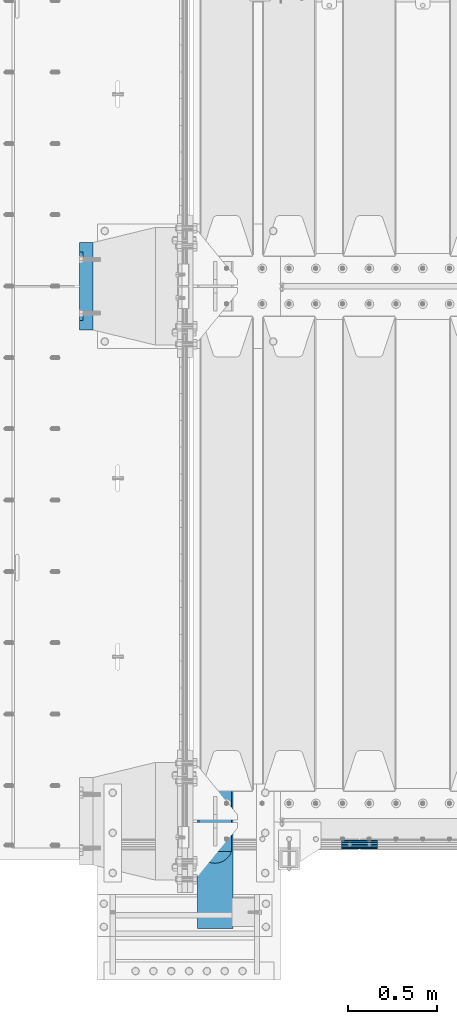
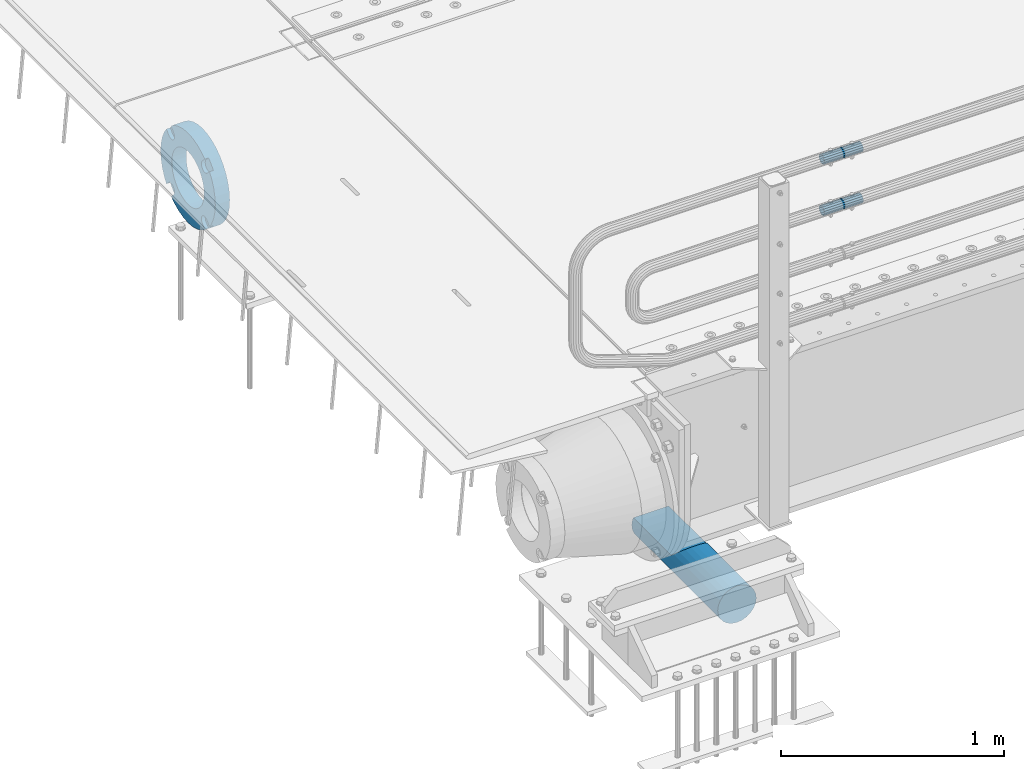
# One storey, part 106 of 193: 4 beams.
"""IFC2X3 building model written with IfcOpenShell, lengths in millimetres."""

from ifc_helpers import new_model, si_unit, frame, origin_with_axes, place, context, subcontext, project, spatial, faceted_brep, material, type_object, element, save


model = new_model("IFC2X3")

# Units and contexts
model_context = context("Model", 3, precision=1e-05, world=origin_with_axes())
body_context = subcontext(model_context, "Body", "Model", "MODEL_VIEW")
ifc_project = project(units=[si_unit("LENGTHUNIT", "METRE", prefix="MILLI"), si_unit("AREAUNIT", "SQUARE_METRE"), si_unit("VOLUMEUNIT", "CUBIC_METRE"), si_unit("MASSUNIT", "GRAM", prefix="KILO"), si_unit("TIMEUNIT", "SECOND"), si_unit("PLANEANGLEUNIT", "RADIAN"), si_unit("SOLIDANGLEUNIT", "STERADIAN"), si_unit("THERMODYNAMICTEMPERATUREUNIT", "DEGREE_CELSIUS"), si_unit("LUMINOUSINTENSITYUNIT", "LUMEN")], contexts=[model_context])

# Site, building, storey
site_placement = place(None, origin_with_axes())
site = spatial("IfcSite", under=ifc_project, at=site_placement, CompositionType="ELEMENT")
building_placement = place(site_placement, origin_with_axes())
building = spatial("IfcBuilding", under=site, at=building_placement, Name="Standard", CompositionType="ELEMENT")
storey_placement = place(building_placement, origin_with_axes())
storey = spatial("IfcBuildingStorey", under=building, at=storey_placement, Name="Undefined", CompositionType="ELEMENT", Elevation=0.0)

# Beams
ifc_material_1 = material(Name="STEEL/S355N")
beam_type_1 = type_object("IfcBeamType", Name="D200", PredefinedType="NOTDEFINED")
beam_1_placement = place(storey_placement, frame((-42315.0, 23400.0, -928.0), z_axis=(0.0, 0.0, 1.0), x_axis=(0.0, 1.0, 0.0)))
element("IfcBeam", 1, at=beam_1_placement, inside=storey, type_object=beam_type_1, material=ifc_material_1, ObjectType="D200", context=body_context, shape_type="Brep", body=[
    faceted_brep([(417.294117647056, 86.6025403784442, 50.0), (395.365164344952, 70.7106781186521, 70.7106781186548), (378.538486658119, 50.0, 86.6025403784439), (367.960794863509, 25.88190451025, 96.5925826289068), (364.352941176472, 0.0, 100.0), (367.960794863509, -25.88190451025, 96.5925826289068), (378.538486658119, -50.0, 86.6025403784439), (395.365164344952, -70.7106781186521, 70.7106781186548), (417.294117647056, -86.6025403784442, 50.0), (430.0, -91.5731031269243, 38.0), (430.0, 91.573103126917, 38.0), (770.0, -91.5731031269243, 37.9999999999994), (770.0, 91.5731031269243, 37.9999999999994), (0.0, -96.5925826289094, 25.8819045102521), (0.0, -86.6025403784442, 50.0), (0.0, -70.7106781186521, 70.7106781186548), (0.0, -50.0, 86.6025403784439), (0.0, -25.88190451025, 96.5925826289068), (0.0, 0.0, 100.0), (0.0, 25.88190451025, 96.5925826289068), (0.0, 50.0, 86.6025403784439), (0.0, 70.7106781186521, 70.7106781186548), (0.0, 86.6025403784442, 50.0), (0.0, 96.5925826289094, 25.8819045102521), (0.0, 100.0, 0.0), (0.0, 96.5925826289094, -25.8819045102521), (0.0, 86.6025403784442, -50.0), (0.0, 70.7106781186521, -70.7106781186548), (0.0, 50.0, -86.6025403784438), (0.0, 25.88190451025, -96.5925826289067), (0.0, 0.0, -100.0), (0.0, -25.88190451025, -96.5925826289069), (0.0, -50.0, -86.6025403784439), (0.0, -70.7106781186521, -70.7106781186548), (0.0, -86.6025403784442, -50.0), (0.0, -96.5925826289094, -25.8819045102522), (0.0, -100.0, 0.0), (770.0, 96.5925826289094, 25.8819045102521), (770.0, 100.0, 0.0), (770.0, 96.5925826289094, -25.8819045102521), (770.0, 86.6025403784442, -50.0), (770.0, 70.7106781186521, -70.7106781186548), (770.0, 50.0, -86.6025403784438), (770.0, 25.88190451025, -96.5925826289067), (770.0, 0.0, -100.0), (770.0, -25.88190451025, -96.5925826289069), (770.0, -50.0, -86.6025403784439), (770.0, -70.7106781186521, -70.7106781186548), (770.0, -86.6025403784442, -50.0), (770.0, -96.5925826289094, -25.8819045102522), (770.0, -100.0, 0.0), (770.0, -96.5925826289094, 25.8819045102521)], [[[0, 1, 2, 3, 4, 5, 6, 7, 8, 9, 10]], [[10, 9, 11, 12]], [[13, 14, 15, 16, 17, 18, 19, 20, 21, 22, 23, 24, 25, 26, 27, 28, 29, 30, 31, 32, 33, 34, 35, 36]], [[24, 23, 37, 38]], [[25, 24, 38, 39]], [[26, 25, 39, 40]], [[27, 26, 40, 41]], [[28, 27, 41, 42]], [[29, 28, 42, 43]], [[30, 29, 43, 44]], [[31, 30, 44, 45]], [[32, 31, 45, 46]], [[33, 32, 46, 47]], [[34, 33, 47, 48]], [[35, 34, 48, 49]], [[36, 35, 49, 50]], [[13, 36, 50, 51]], [[14, 13, 51, 11, 9, 8]], [[15, 14, 8, 7]], [[16, 15, 7, 6]], [[17, 16, 6, 5]], [[18, 17, 5, 4]], [[19, 18, 4, 3]], [[20, 19, 3, 2]], [[21, 20, 2, 1]], [[22, 21, 1, 0]], [[37, 23, 22, 0, 10, 12]], [[51, 50, 49, 48, 47, 46, 45, 44, 43, 42, 41, 40, 39, 38, 37, 12, 11]]]),
])
ifc_material_2 = material()
beam_type_2 = type_object("IfcBeamType", PredefinedType="NOTDEFINED")
beam_2_placement = place(storey_placement, frame((-41605.0024970001, 23870.1500000004, 969.849999999747), z_axis=(0.0, 0.0, 1.0), x_axis=(1.0, 0.0, 0.0)))
element("IfcBeam", 2, at=beam_2_placement, inside=storey, type_object=beam_type_2, material=ifc_material_2, context=body_context, shape_type="Brep", body=[
    faceted_brep([(0.0, -21.9000000000015, 0.0), (0.0, -20.232961761998, 8.38076716879547), (200.0, -20.232961761998, 8.38076716879547), (200.0, -21.9000000000015, 0.0), (0.0, -15.4856385079838, 15.4856385079854), (200.0, -15.4856385079838, 15.4856385079854), (0.0, -8.38076716879368, 20.2329617619972), (200.0, -8.38076716879368, 20.2329617619972), (0.0, 0.0, 21.9), (200.0, 0.0, 21.9), (0.0, 8.38076716879368, 20.2329617619972), (200.0, 8.38076716879368, 20.2329617619972), (0.0, 15.4856385079838, 15.4856385079854), (200.0, 15.4856385079838, 15.4856385079854), (0.0, 20.232961761998, 8.38076716879547), (200.0, 20.232961761998, 8.38076716879547), (0.0, 21.9000000000015, 0.0), (200.0, 21.9000000000015, 0.0), (0.0, 20.232961761998, -8.38076716879547), (200.0, 20.232961761998, -8.38076716879547), (0.0, 15.4856385079838, -15.4856385079854), (200.0, 15.4856385079838, -15.4856385079854), (0.0, 8.38076716879368, -20.2329617619972), (200.0, 8.38076716879368, -20.2329617619972), (0.0, 0.0, -21.9), (200.0, 0.0, -21.9), (0.0, -8.38076716879368, -20.2329617619972), (200.0, -8.38076716879368, -20.2329617619972), (0.0, -15.4856385079838, -15.4856385079854), (200.0, -15.4856385079838, -15.4856385079854), (0.0, -20.232961761998, -8.38076716879547), (200.0, -20.232961761998, -8.38076716879547), (0.0, -25.5, 0.0), (0.0, -23.5589280790373, -9.7584275253098), (200.0, -23.5589280790373, -9.7584275253098), (200.0, -25.5, 0.0), (0.0, -18.0312229202573, -18.031222920257), (200.0, -18.0312229202573, -18.031222920257), (0.0, -9.75842752531025, -23.5589280790378), (200.0, -9.75842752531025, -23.5589280790378), (0.0, 0.0, -25.5), (200.0, 0.0, -25.5), (0.0, 9.75842752531025, -23.5589280790378), (200.0, 9.75842752531025, -23.5589280790378), (0.0, 18.0312229202573, -18.031222920257), (200.0, 18.0312229202573, -18.031222920257), (0.0, 23.5589280790373, -9.7584275253098), (200.0, 23.5589280790373, -9.7584275253098), (0.0, 25.5, 0.0), (200.0, 25.5, 0.0), (0.0, 23.5589280790373, 9.7584275253098), (200.0, 23.5589280790373, 9.7584275253098), (0.0, 18.0312229202573, 18.031222920257), (200.0, 18.0312229202573, 18.031222920257), (0.0, 9.75842752531025, 23.5589280790378), (200.0, 9.75842752531025, 23.5589280790378), (0.0, 0.0, 25.5), (200.0, 0.0, 25.5), (0.0, -9.75842752531025, 23.5589280790378), (200.0, -9.75842752531025, 23.5589280790378), (0.0, -18.0312229202573, 18.031222920257), (200.0, -18.0312229202573, 18.031222920257), (0.0, -23.5589280790373, 9.7584275253098), (200.0, -23.5589280790373, 9.7584275253098)], [[[0, 1, 2, 3]], [[1, 4, 5, 2]], [[4, 6, 7, 5]], [[6, 8, 9, 7]], [[8, 10, 11, 9]], [[10, 12, 13, 11]], [[12, 14, 15, 13]], [[14, 16, 17, 15]], [[16, 18, 19, 17]], [[18, 20, 21, 19]], [[20, 22, 23, 21]], [[22, 24, 25, 23]], [[24, 26, 27, 25]], [[26, 28, 29, 27]], [[28, 30, 31, 29]], [[30, 0, 3, 31]], [[32, 33, 34, 35]], [[33, 36, 37, 34]], [[36, 38, 39, 37]], [[38, 40, 41, 39]], [[40, 42, 43, 41]], [[42, 44, 45, 43]], [[44, 46, 47, 45]], [[46, 48, 49, 47]], [[48, 50, 51, 49]], [[50, 52, 53, 51]], [[52, 54, 55, 53]], [[54, 56, 57, 55]], [[56, 58, 59, 57]], [[58, 60, 61, 59]], [[60, 62, 63, 61]], [[62, 32, 35, 63]], [[37, 39, 41, 43, 45, 47, 49, 51, 53, 55, 57, 59, 61, 63, 35, 34], [5, 7, 9, 11, 13, 15, 17, 19, 21, 23, 25, 27, 29, 31, 3, 2]], [[62, 60, 58, 56, 54, 52, 50, 48, 46, 44, 42, 40, 38, 36, 33, 32], [30, 28, 26, 24, 22, 20, 18, 16, 14, 12, 10, 8, 6, 4, 1, 0]]]),
])
beam_3_placement = place(storey_placement, frame((-41605.0024970001, 23870.1500000004, 689.849999999747), z_axis=(0.0, 0.0, 1.0), x_axis=(1.0, 0.0, 0.0)))
element("IfcBeam", 3, at=beam_3_placement, inside=storey, type_object=beam_type_2, material=ifc_material_2, context=body_context, shape_type="Brep", body=[
    faceted_brep([(0.0, -21.9000000000015, 0.0), (0.0, -20.232961761998, 8.38076716879547), (200.0, -20.232961761998, 8.38076716879547), (200.0, -21.9000000000015, 0.0), (0.0, -15.4856385079838, 15.4856385079854), (200.0, -15.4856385079838, 15.4856385079854), (0.0, -8.38076716879368, 20.2329617619972), (200.0, -8.38076716879368, 20.2329617619972), (0.0, 0.0, 21.9), (200.0, 0.0, 21.9), (0.0, 8.38076716879368, 20.2329617619972), (200.0, 8.38076716879368, 20.2329617619972), (0.0, 15.4856385079838, 15.4856385079854), (200.0, 15.4856385079838, 15.4856385079854), (0.0, 20.232961761998, 8.38076716879547), (200.0, 20.232961761998, 8.38076716879547), (0.0, 21.9000000000015, 0.0), (200.0, 21.9000000000015, 0.0), (0.0, 20.232961761998, -8.38076716879547), (200.0, 20.232961761998, -8.38076716879547), (0.0, 15.4856385079838, -15.4856385079854), (200.0, 15.4856385079838, -15.4856385079854), (0.0, 8.38076716879368, -20.2329617619972), (200.0, 8.38076716879368, -20.2329617619972), (0.0, 0.0, -21.9), (200.0, 0.0, -21.9), (0.0, -8.38076716879368, -20.2329617619972), (200.0, -8.38076716879368, -20.2329617619972), (0.0, -15.4856385079838, -15.4856385079854), (200.0, -15.4856385079838, -15.4856385079854), (0.0, -20.232961761998, -8.38076716879547), (200.0, -20.232961761998, -8.38076716879547), (0.0, -25.5, 0.0), (0.0, -23.5589280790373, -9.7584275253098), (200.0, -23.5589280790373, -9.7584275253098), (200.0, -25.5, 0.0), (0.0, -18.0312229202573, -18.031222920257), (200.0, -18.0312229202573, -18.031222920257), (0.0, -9.75842752531025, -23.5589280790378), (200.0, -9.75842752531025, -23.5589280790378), (0.0, 0.0, -25.5), (200.0, 0.0, -25.5), (0.0, 9.75842752531025, -23.5589280790378), (200.0, 9.75842752531025, -23.5589280790378), (0.0, 18.0312229202573, -18.031222920257), (200.0, 18.0312229202573, -18.031222920257), (0.0, 23.5589280790373, -9.7584275253098), (200.0, 23.5589280790373, -9.7584275253098), (0.0, 25.5, 0.0), (200.0, 25.5, 0.0), (0.0, 23.5589280790373, 9.7584275253098), (200.0, 23.5589280790373, 9.7584275253098), (0.0, 18.0312229202573, 18.031222920257), (200.0, 18.0312229202573, 18.031222920257), (0.0, 9.75842752531025, 23.5589280790378), (200.0, 9.75842752531025, 23.5589280790378), (0.0, 0.0, 25.5), (200.0, 0.0, 25.5), (0.0, -9.75842752531025, 23.5589280790378), (200.0, -9.75842752531025, 23.5589280790378), (0.0, -18.0312229202573, 18.031222920257), (200.0, -18.0312229202573, 18.031222920257), (0.0, -23.5589280790373, 9.7584275253098), (200.0, -23.5589280790373, 9.7584275253098)], [[[0, 1, 2, 3]], [[1, 4, 5, 2]], [[4, 6, 7, 5]], [[6, 8, 9, 7]], [[8, 10, 11, 9]], [[10, 12, 13, 11]], [[12, 14, 15, 13]], [[14, 16, 17, 15]], [[16, 18, 19, 17]], [[18, 20, 21, 19]], [[20, 22, 23, 21]], [[22, 24, 25, 23]], [[24, 26, 27, 25]], [[26, 28, 29, 27]], [[28, 30, 31, 29]], [[30, 0, 3, 31]], [[32, 33, 34, 35]], [[33, 36, 37, 34]], [[36, 38, 39, 37]], [[38, 40, 41, 39]], [[40, 42, 43, 41]], [[42, 44, 45, 43]], [[44, 46, 47, 45]], [[46, 48, 49, 47]], [[48, 50, 51, 49]], [[50, 52, 53, 51]], [[52, 54, 55, 53]], [[54, 56, 57, 55]], [[56, 58, 59, 57]], [[58, 60, 61, 59]], [[60, 62, 63, 61]], [[62, 32, 35, 63]], [[37, 39, 41, 43, 45, 47, 49, 51, 53, 55, 57, 59, 61, 63, 35, 34], [5, 7, 9, 11, 13, 15, 17, 19, 21, 23, 25, 27, 29, 31, 3, 2]], [[62, 60, 58, 56, 54, 52, 50, 48, 46, 44, 42, 40, 38, 36, 33, 32], [30, 28, 26, 24, 22, 20, 18, 16, 14, 12, 10, 8, 6, 4, 1, 0]]]),
])
ifc_material_3 = material(Name="SCN-500-E2")
beam_type_3 = type_object("IfcBeamType", PredefinedType="NOTDEFINED")
beam_4_placement = place(storey_placement, frame((-43000.0, 27000.0000014662, -515.0), z_axis=(0.0, 0.0, 1.0), x_axis=(-1.0, 0.0, 0.0)))
element("IfcBeam", 4, at=beam_4_placement, inside=storey, type_object=beam_type_3, material=ifc_material_3, context=body_context, shape_type="Brep", body=[
    faceted_brep([(75.0, 192.717024793295, -150.290616455866), (75.0, 171.473395903973, -129.046987566545), (55.0, 171.473395903973, -129.046987566545), (55.0, 192.717024793295, -150.290616455869), (75.0, 167.467485558918, -125.685629673588), (55.0, 167.467485558918, -125.685629673588), (75.0, 162.938740320609, -123.070957391173), (55.0, 162.938740320609, -123.070957391173), (75.0, 158.024763821468, -121.282416213608), (55.0, 158.024763821468, -121.282416213608), (75.0, 152.874864750829, -120.374350059533), (55.0, 152.874864750829, -120.374350059533), (75.0, 147.645520185979, -120.37435005953), (55.0, 147.645520185979, -120.37435005953), (75.0, 142.495621115344, -121.282416213611), (55.0, 142.495621115344, -121.282416213611), (75.0, 137.58164461621, -123.070957391175), (55.0, 137.58164461621, -123.070957391175), (75.0, 133.052899377915, -125.685629673596), (55.0, 133.052899377915, -125.685629673596), (75.0, 129.04698903278, -129.046987566545), (55.0, 129.04698903278, -129.046987566545), (75.0, 125.685631139655, -133.052897911658), (55.0, 125.685631139655, -133.052897911658), (75.0, 123.070958857214, -137.581643149977), (55.0, 123.070958857214, -137.581643149977), (75.0, 121.282417679631, -142.49561964913), (55.0, 121.282417679631, -142.49561964913), (75.0, 120.374351525545, -147.64551871979), (55.0, 120.374351525545, -147.64551871979), (75.0, 120.374351525537, -152.874863284665), (55.0, 120.374351525537, -152.874863284665), (75.0, 121.282417679613, -158.024762355333), (55.0, 121.282417679613, -158.024762355333), (75.0, 123.070958857188, -162.938738854498), (55.0, 123.070958857188, -162.938738854498), (75.0, 125.685631139622, -167.467484092835), (55.0, 125.685631139622, -167.467484092835), (75.0, 129.04698903278, -171.473394437738), (55.0, 129.04698903278, -171.473394437738), (55.0, 150.290618180636, -192.717023585595), (75.0, 150.290618180639, -192.717023585596), (55.0, 157.482964373201, -187.68088856415), (55.0, 187.680888564151, -157.482964373202), (75.0, -192.717023585599, 150.290618180639), (75.0, -171.4733929715, 129.046987566545), (55.0, -171.4733929715, 129.046987566545), (55.0, -192.717023585596, 150.290618180642), (75.0, -167.467482626445, 125.685629673588), (55.0, -167.467482626445, 125.685629673588), (75.0, -162.938737388136, 123.070957391173), (55.0, -162.938737388136, 123.070957391173), (75.0, -158.024760888995, 121.282416213608), (55.0, -158.024760888995, 121.282416213608), (75.0, -152.874861818356, 120.374350059533), (55.0, -152.874861818356, 120.374350059533), (75.0, -147.645517253506, 120.37435005953), (55.0, -147.645517253506, 120.37435005953), (75.0, -142.495618182871, 121.282416213611), (55.0, -142.495618182871, 121.282416213611), (75.0, -137.581641683737, 123.070957391176), (55.0, -137.581641683737, 123.070957391176), (75.0, -133.052896445442, 125.685629673596), (55.0, -133.052896445442, 125.685629673596), (75.0, -129.046986100308, 129.046987566545), (55.0, -129.046986100308, 129.046987566545), (75.0, -125.685628207182, 133.052897911658), (55.0, -125.685628207182, 133.052897911658), (75.0, -123.070955924741, 137.581643149977), (55.0, -123.070955924741, 137.581643149977), (75.0, -121.282414747158, 142.49561964913), (55.0, -121.282414747158, 142.49561964913), (75.0, -120.374348593072, 147.64551871979), (55.0, -120.374348593072, 147.64551871979), (75.0, -120.374348593065, 152.874863284665), (55.0, -120.374348593065, 152.874863284665), (75.0, -121.28241474714, 158.024762355333), (55.0, -121.28241474714, 158.024762355333), (75.0, -123.070955924715, 162.938738854498), (55.0, -123.070955924715, 162.938738854498), (75.0, -125.685628207149, 167.467484092835), (55.0, -125.685628207149, 167.467484092835), (75.0, -129.046986100308, 171.473394437738), (55.0, -129.046986100308, 171.473394437738), (55.0, -150.290616455863, 192.717024793293), (75.0, -150.290616455866, 192.717024793293), (75.0, 150.290618180636, 192.717023585598), (75.0, 129.04698903278, 171.473394437739), (55.0, 129.04698903278, 171.473394437739), (55.0, 150.290618180636, 192.717023585597), (75.0, 125.685631139822, 167.467484092685), (55.0, 125.685631139822, 167.467484092685), (75.0, 123.07095885741, 162.938738854374), (55.0, 123.07095885741, 162.938738854374), (75.0, 121.282417679842, 158.024762355234), (55.0, 121.282417679842, 158.024762355234), (75.0, 120.37435152577, 152.874863284594), (55.0, 120.37435152577, 152.874863284594), (75.0, 120.374351525767, 147.645518719745), (55.0, 120.374351525767, 147.645518719745), (75.0, 121.282417679846, 142.495619649111), (55.0, 121.282417679846, 142.495619649111), (75.0, 123.07095885741, 137.581643149976), (55.0, 123.07095885741, 137.581643149976), (75.0, 125.68563113983, 133.05289791168), (55.0, 125.68563113983, 133.05289791168), (75.0, 129.04698903278, 129.046987566546), (55.0, 129.04698903278, 129.046987566546), (75.0, 133.052899377893, 125.685629673422), (55.0, 133.052899377893, 125.685629673422), (75.0, 137.581644616213, 123.070957390979), (55.0, 137.581644616213, 123.070957390979), (75.0, 142.495621115366, 121.282416213396), (55.0, 142.495621115366, 121.282416213396), (75.0, 147.645520186026, 120.374350059311), (55.0, 147.645520186026, 120.374350059311), (75.0, 152.874864750902, 120.374350059303), (55.0, 152.874864750902, 120.374350059303), (75.0, 158.02476382157, 121.28241621338), (55.0, 158.02476382157, 121.28241621338), (75.0, 162.938740320733, 123.070957390956), (55.0, 162.938740320733, 123.070957390956), (75.0, 167.467485559071, 125.685629673386), (55.0, 167.467485559071, 125.685629673386), (75.0, 171.473395903973, 129.046987566546), (55.0, 171.473395903973, 129.046987566546), (55.0, 192.717024793295, 150.29061645587), (75.0, 192.717024793295, 150.290616455869), (0.0, 212.176223927188, -122.5), (0.0, 230.224692092546, -83.7949351147888), (75.0, 230.224692092546, -83.7949351147888), (75.0, 212.176223927188, -122.5), (0.0, 241.277899487992, -42.5438035283978), (75.0, 241.277899487992, -42.5438035283978), (0.0, 245.0, 0.0), (75.0, 245.0, 0.0), (0.0, 241.277899487992, 42.543803528398), (75.0, 241.277899487992, 42.543803528398), (0.0, 230.224692092546, 83.7949351147889), (75.0, 230.224692092546, 83.7949351147889), (0.0, 212.176223927188, 122.5), (75.0, 212.176223927188, 122.5), (0.0, 187.680888564151, 157.482964373202), (55.0, 187.680888564151, 157.482964373202), (0.0, 157.482964373201, 187.68088856415), (55.0, 157.482964373201, 187.68088856415), (0.0, 122.5, 212.176223927187), (75.0, 122.5, 212.176223927187), (0.0, 83.7949351147872, 230.224692092548), (75.0, 83.7949351147872, 230.224692092548), (0.0, 42.5438035283987, 241.277899487991), (75.0, 42.5438035283987, 241.277899487991), (0.0, 0.0, 245.0), (75.0, 0.0, 245.0), (0.0, -42.5438035283987, 241.277899487991), (75.0, -42.5438035283987, 241.277899487991), (0.0, -83.7949351147872, 230.224692092548), (75.0, -83.7949351147872, 230.224692092548), (0.0, -122.5, 212.176223927187), (75.0, -122.5, 212.176223927187), (0.0, -157.482964373201, 187.68088856415), (55.0, -157.482964373201, 187.68088856415), (0.0, -187.680888564151, 157.482964373202), (55.0, -187.680888564151, 157.482964373202), (0.0, -212.176223927188, 122.5), (75.0, -212.176223927188, 122.5), (0.0, -230.224692092546, 83.7949351147888), (75.0, -230.224692092546, 83.7949351147888), (0.0, -241.277899487992, 42.5438035283979), (75.0, -241.277899487992, 42.5438035283979), (0.0, -245.0, 0.0), (75.0, -245.0, 0.0), (0.0, -187.680888564151, -157.482964373202), (0.0, -157.482964373201, -187.68088856415), (55.0, -157.482964373201, -187.68088856415), (55.0, -187.680888564151, -157.482964373202), (0.0, 83.7949351147872, -230.224692092547), (0.0, 122.5, -212.176223927187), (75.0, 122.5, -212.176223927187), (75.0, 83.7949351147872, -230.224692092547), (0.0, 42.5438035283987, -241.277899487991), (75.0, 42.5438035283987, -241.277899487991), (0.0, 0.0, -245.0), (75.0, 0.0, -245.0), (0.0, -42.5438035283987, -241.277899487991), (75.0, -42.5438035283987, -241.277899487991), (0.0, -83.7949351147872, -230.224692092548), (75.0, -83.7949351147872, -230.224692092548), (0.0, -122.5, -212.176223927187), (75.0, -122.5, -212.176223927187), (75.0, -150.290616455863, -192.717024793297), (55.0, -150.290616455863, -192.717024793296), (55.0, -129.046986100308, -171.473394437739), (55.0, -125.68562820735, -167.467484092685), (55.0, -123.070955924937, -162.938738854373), (55.0, -121.282414747369, -158.024762355234), (55.0, -120.374348593297, -152.874863284594), (55.0, -120.374348593294, -147.645518719745), (55.0, -121.282414747373, -142.495619649111), (55.0, -123.070955924937, -137.581643149976), (55.0, -125.685628207357, -133.05289791168), (55.0, -129.046986100308, -129.046987566546), (55.0, -133.052896445421, -125.685629673422), (55.0, -137.581641683741, -123.070957390979), (55.0, -142.495618182893, -121.282416213396), (55.0, -147.645517253553, -120.37435005931), (55.0, -152.874861818429, -120.374350059303), (55.0, -158.024760889097, -121.28241621338), (55.0, -162.93873738826, -123.070957390956), (55.0, -167.467482626598, -125.685629673386), (55.0, -171.4733929715, -129.046987566546), (55.0, -192.717023585596, -150.290618180642), (75.0, -129.046986100308, -171.473394437739), (75.0, -125.68562820735, -167.467484092685), (75.0, -123.070955924937, -162.938738854373), (75.0, -121.282414747369, -158.024762355234), (75.0, -120.374348593297, -152.874863284594), (75.0, -120.374348593294, -147.645518719745), (75.0, -121.282414747373, -142.495619649111), (75.0, -123.070955924937, -137.581643149976), (75.0, -125.685628207357, -133.05289791168), (75.0, -129.046986100308, -129.046987566546), (75.0, -133.052896445421, -125.685629673422), (75.0, -137.581641683741, -123.070957390979), (75.0, -142.495618182893, -121.282416213396), (75.0, -147.645517253553, -120.37435005931), (75.0, -152.874861818429, -120.374350059303), (75.0, -158.024760889097, -121.28241621338), (75.0, -162.93873738826, -123.070957390956), (75.0, -167.467482626598, -125.685629673386), (75.0, -171.4733929715, -129.046987566546), (75.0, -192.717023585596, -150.290618180643), (75.0, -212.176223927188, -122.5), (0.0, -212.176223927188, -122.5), (0.0, -230.224692092546, -83.794935114789), (75.0, -230.224692092546, -83.794935114789), (0.0, -241.277899487992, -42.5438035283979), (75.0, -241.277899487992, -42.5438035283979), (0.0, 187.680888564151, -157.482964373202), (0.0, 157.482964373201, -187.68088856415), (0.0, -142.797124186771, -25.1789857617049), (0.0, -136.255430013956, -49.592920782222), (0.0, -125.573683548744, -72.5), (0.0, -111.076444252252, -93.2042034045483), (0.0, -93.204203404548, -111.076444252252), (0.0, -72.5, -125.573683548744), (0.0, -49.5929207822228, -136.255430013957), (0.0, -25.1789857617041, -142.79712418677), (0.0, 0.0, -145.0), (0.0, 25.1789857617041, -142.79712418677), (0.0, 49.5929207822228, -136.255430013957), (0.0, 72.5, -125.573683548744), (0.0, 93.204203404548, -111.076444252252), (0.0, 111.076444252252, -93.2042034045483), (0.0, 125.573683548744, -72.5), (0.0, 136.255430013956, -49.592920782222), (0.0, 142.797124186771, -25.178985761705), (0.0, 145.0, 0.0), (0.0, 142.797124186771, 25.1789857617048), (0.0, 136.255430013956, 49.5929207822219), (0.0, 125.573683548744, 72.4999999999999), (0.0, 111.076444252252, 93.2042034045482), (0.0, 93.204203404548, 111.076444252252), (0.0, 72.5, 125.573683548744), (0.0, 49.5929207822228, 136.255430013957), (0.0, 25.1789857617041, 142.79712418677), (0.0, 0.0, 145.0), (0.0, -25.1789857617041, 142.79712418677), (0.0, -49.5929207822228, 136.255430013957), (0.0, -72.5, 125.573683548744), (0.0, -93.204203404548, 111.076444252252), (0.0, -111.076444252252, 93.2042034045483), (0.0, -125.573683548744, 72.5000000000001), (0.0, -136.255430013956, 49.5929207822221), (0.0, -142.797124186771, 25.1789857617049), (0.0, -145.0, 0.0), (75.0, -145.0, 0.0), (75.0, -142.797124186771, -25.1789857617049), (75.0, -136.255430013956, -49.592920782222), (75.0, -125.573683548744, -72.5), (75.0, -111.076444252252, -93.2042034045483), (75.0, -93.204203404548, -111.076444252252), (75.0, -72.5, -125.573683548744), (75.0, -49.5929207822228, -136.255430013957), (75.0, -25.1789857617041, -142.79712418677), (75.0, 0.0, -145.0), (75.0, 25.1789857617041, -142.79712418677), (75.0, 49.5929207822228, -136.255430013957), (75.0, 72.5, -125.573683548744), (75.0, 93.204203404548, -111.076444252252), (75.0, 111.076444252252, -93.2042034045483), (75.0, 125.573683548744, -72.5), (75.0, 136.255430013956, -49.592920782222), (75.0, 142.797124186771, -25.178985761705), (75.0, 145.0, 0.0), (75.0, 142.797124186771, 25.1789857617048), (75.0, 136.255430013956, 49.5929207822219), (75.0, 125.573683548744, 72.4999999999999), (75.0, 111.076444252252, 93.2042034045482), (75.0, 93.204203404548, 111.076444252252), (75.0, 72.5, 125.573683548744), (75.0, 49.5929207822228, 136.255430013957), (75.0, 25.1789857617041, 142.79712418677), (75.0, 0.0, 145.0), (75.0, -25.1789857617041, 142.79712418677), (75.0, -49.5929207822228, 136.255430013957), (75.0, -72.5, 125.573683548744), (75.0, -93.204203404548, 111.076444252252), (75.0, -111.076444252252, 93.2042034045483), (75.0, -125.573683548744, 72.5000000000001), (75.0, -136.255430013956, 49.5929207822221), (75.0, -142.797124186771, 25.1789857617049)], [[[0, 1, 2, 3]], [[4, 5, 2, 1]], [[6, 7, 5, 4]], [[8, 9, 7, 6]], [[10, 11, 9, 8]], [[12, 13, 11, 10]], [[14, 15, 13, 12]], [[16, 17, 15, 14]], [[18, 19, 17, 16]], [[20, 21, 19, 18]], [[22, 23, 21, 20]], [[24, 25, 23, 22]], [[26, 27, 25, 24]], [[28, 29, 27, 26]], [[30, 31, 29, 28]], [[32, 33, 31, 30]], [[34, 35, 33, 32]], [[36, 37, 35, 34]], [[38, 39, 37, 36]], [[40, 39, 38, 41]], [[42, 43, 3, 2, 5, 7, 9, 11, 13, 15, 17, 19, 21, 23, 25, 27, 29, 31, 33, 35, 37, 39, 40]], [[44, 45, 46, 47]], [[48, 49, 46, 45]], [[50, 51, 49, 48]], [[52, 53, 51, 50]], [[54, 55, 53, 52]], [[56, 57, 55, 54]], [[58, 59, 57, 56]], [[60, 61, 59, 58]], [[62, 63, 61, 60]], [[64, 65, 63, 62]], [[66, 67, 65, 64]], [[68, 69, 67, 66]], [[70, 71, 69, 68]], [[72, 73, 71, 70]], [[74, 75, 73, 72]], [[76, 77, 75, 74]], [[78, 79, 77, 76]], [[80, 81, 79, 78]], [[82, 83, 81, 80]], [[84, 83, 82, 85]], [[86, 87, 88, 89]], [[90, 91, 88, 87]], [[92, 93, 91, 90]], [[94, 95, 93, 92]], [[96, 97, 95, 94]], [[98, 99, 97, 96]], [[100, 101, 99, 98]], [[102, 103, 101, 100]], [[104, 105, 103, 102]], [[106, 107, 105, 104]], [[108, 109, 107, 106]], [[110, 111, 109, 108]], [[112, 113, 111, 110]], [[114, 115, 113, 112]], [[116, 117, 115, 114]], [[118, 119, 117, 116]], [[120, 121, 119, 118]], [[122, 123, 121, 120]], [[124, 125, 123, 122]], [[126, 125, 124, 127]], [[128, 129, 130, 131]], [[129, 132, 133, 130]], [[132, 134, 135, 133]], [[134, 136, 137, 135]], [[136, 138, 139, 137]], [[138, 140, 141, 139]], [[127, 141, 140, 142, 143, 126]], [[142, 144, 145, 143]], [[89, 88, 91, 93, 95, 97, 99, 101, 103, 105, 107, 109, 111, 113, 115, 117, 119, 121, 123, 125, 126, 143, 145]], [[144, 146, 147, 86, 89, 145]], [[146, 148, 149, 147]], [[148, 150, 151, 149]], [[150, 152, 153, 151]], [[152, 154, 155, 153]], [[154, 156, 157, 155]], [[156, 158, 159, 157]], [[85, 159, 158, 160, 161, 84]], [[160, 162, 163, 161]], [[47, 46, 49, 51, 53, 55, 57, 59, 61, 63, 65, 67, 69, 71, 73, 75, 77, 79, 81, 83, 84, 161, 163]], [[162, 164, 165, 44, 47, 163]], [[164, 166, 167, 165]], [[166, 168, 169, 167]], [[168, 170, 171, 169]], [[172, 173, 174, 175]], [[176, 177, 178, 179]], [[180, 176, 179, 181]], [[182, 180, 181, 183]], [[184, 182, 183, 185]], [[186, 184, 185, 187]], [[188, 186, 187, 189]], [[173, 188, 189, 190, 191, 174]], [[175, 174, 191, 192, 193, 194, 195, 196, 197, 198, 199, 200, 201, 202, 203, 204, 205, 206, 207, 208, 209, 210, 211]], [[190, 212, 192, 191]], [[213, 193, 192, 212]], [[214, 194, 193, 213]], [[215, 195, 194, 214]], [[216, 196, 195, 215]], [[217, 197, 196, 216]], [[218, 198, 197, 217]], [[219, 199, 198, 218]], [[220, 200, 199, 219]], [[221, 201, 200, 220]], [[222, 202, 201, 221]], [[223, 203, 202, 222]], [[224, 204, 203, 223]], [[225, 205, 204, 224]], [[226, 206, 205, 225]], [[227, 207, 206, 226]], [[228, 208, 207, 227]], [[229, 209, 208, 228]], [[230, 210, 209, 229]], [[211, 210, 230, 231]], [[232, 233, 172, 175, 211, 231]], [[234, 233, 232, 235]], [[236, 234, 235, 237]], [[170, 236, 237, 171]], [[168, 166, 164, 162, 160, 158, 156, 154, 152, 150, 148, 146, 144, 142, 140, 138, 136, 134, 132, 129, 128, 238, 239, 177, 176, 180, 182, 184, 186, 188, 173, 172, 233, 234, 236, 170], [240, 241, 242, 243, 244, 245, 246, 247, 248, 249, 250, 251, 252, 253, 254, 255, 256, 257, 258, 259, 260, 261, 262, 263, 264, 265, 266, 267, 268, 269, 270, 271, 272, 273, 274, 275]], [[240, 275, 276, 277]], [[241, 240, 277, 278]], [[242, 241, 278, 279]], [[243, 242, 279, 280]], [[244, 243, 280, 281]], [[245, 244, 281, 282]], [[246, 245, 282, 283]], [[247, 246, 283, 284]], [[248, 247, 284, 285]], [[249, 248, 285, 286]], [[250, 249, 286, 287]], [[251, 250, 287, 288]], [[252, 251, 288, 289]], [[253, 252, 289, 290]], [[254, 253, 290, 291]], [[255, 254, 291, 292]], [[256, 255, 292, 293]], [[257, 256, 293, 294]], [[258, 257, 294, 295]], [[259, 258, 295, 296]], [[260, 259, 296, 297]], [[261, 260, 297, 298]], [[262, 261, 298, 299]], [[263, 262, 299, 300]], [[264, 263, 300, 301]], [[265, 264, 301, 302]], [[266, 265, 302, 303]], [[267, 266, 303, 304]], [[268, 267, 304, 305]], [[269, 268, 305, 306]], [[270, 269, 306, 307]], [[271, 270, 307, 308]], [[272, 271, 308, 309]], [[273, 272, 309, 310]], [[274, 273, 310, 311]], [[275, 274, 311, 276]], [[24, 22, 20, 18, 16, 14, 12, 10, 8, 6, 4, 1, 0, 131, 130, 133, 135, 137, 139, 141, 127, 124, 122, 120, 118, 116, 114, 112, 110, 108, 106, 104, 102, 100, 98, 96, 94, 92, 90, 87, 86, 147, 149, 151, 153, 155, 157, 159, 85, 82, 80, 78, 76, 74, 72, 70, 68, 66, 64, 62, 60, 58, 56, 54, 52, 50, 48, 45, 44, 165, 167, 169, 171, 237, 235, 232, 231, 230, 229, 228, 227, 226, 225, 224, 223, 222, 221, 220, 219, 218, 217, 216, 215, 214, 213, 212, 190, 189, 187, 185, 183, 181, 179, 178, 41, 38, 36, 34, 32, 30, 28, 26], [310, 309, 308, 307, 306, 305, 304, 303, 302, 301, 300, 299, 298, 297, 296, 295, 294, 293, 292, 291, 290, 289, 288, 287, 286, 285, 284, 283, 282, 281, 280, 279, 278, 277, 276, 311]], [[238, 128, 131, 0, 3, 43]], [[239, 238, 43, 42]], [[178, 177, 239, 42, 40, 41]]]),
])

save(model, "model.ifc")
